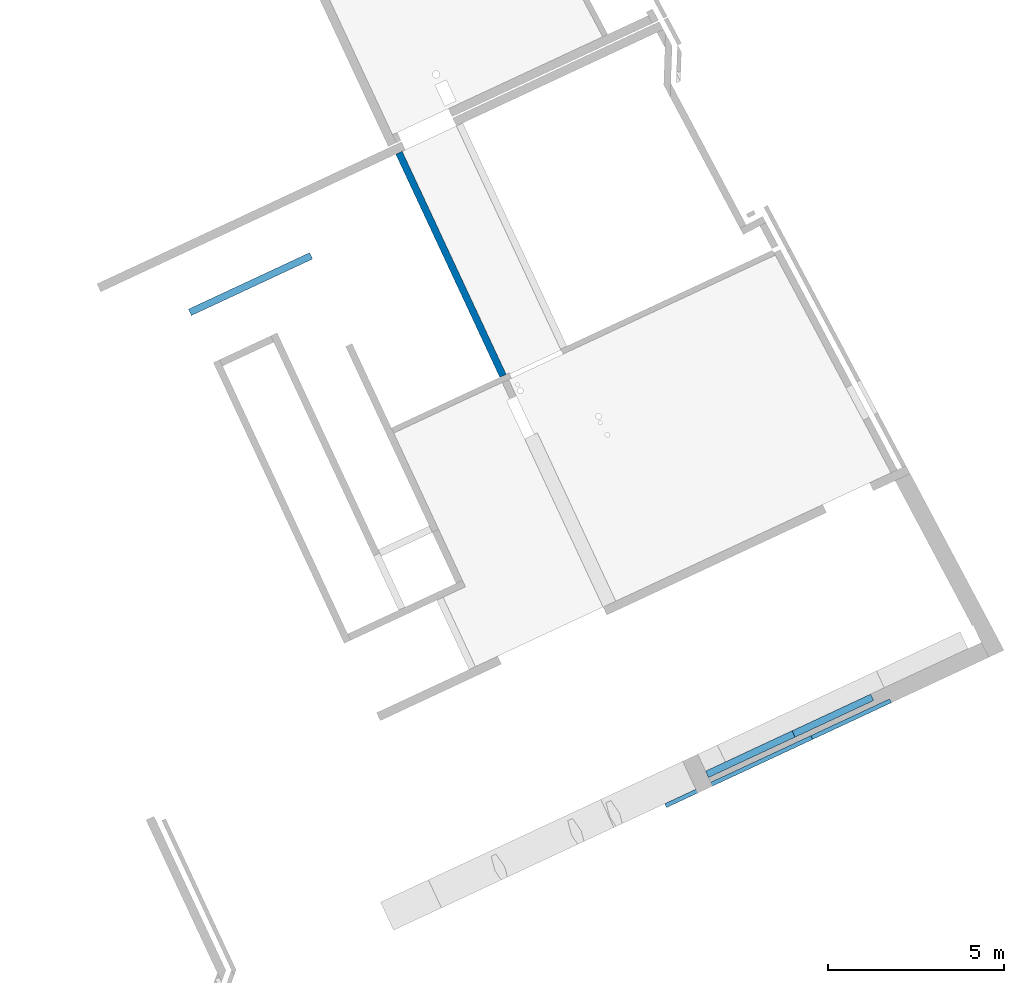
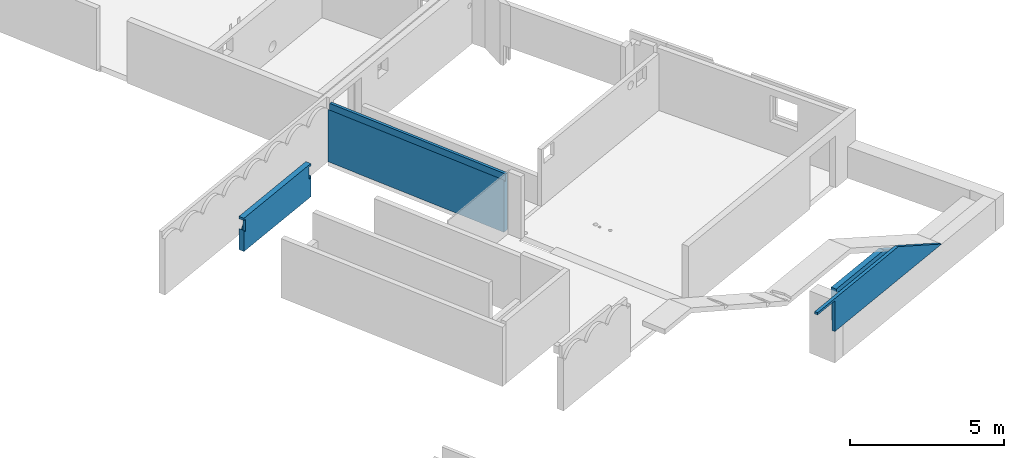
# One storey, part 7 of 13: 4 walls.
"""IFC2X3 building model written with IfcOpenShell, lengths in metres."""

from ifc_helpers import new_model, entity, si_unit, converted_unit, derived_unit, direction, frame, origin, place, context, subcontext, project, spatial, faceted_brep, material, layer, layer_set, type_object, element, save


model = new_model("IFC2X3")

# Units and contexts
model_context = context("Model", 3, precision=1e-05, world=origin(), true_north=direction((6.12303176911189e-17, 1.0)))
body_context = subcontext(model_context, "Body", "Model", "MODEL_VIEW")
ifc_project = project(units=[si_unit("LENGTHUNIT", "METRE"), si_unit("AREAUNIT", "SQUARE_METRE"), si_unit("VOLUMEUNIT", "CUBIC_METRE"), converted_unit("PLANEANGLEUNIT", "DEGREE", entity("IfcRatioMeasure", 0.0174532925199433), si_unit("PLANEANGLEUNIT", "RADIAN"), dimensions=[0, 0, 0, 0, 0, 0, 0]), si_unit("MASSUNIT", "GRAM", prefix="KILO"), derived_unit("MASSDENSITYUNIT", [(si_unit("MASSUNIT", "GRAM", prefix="KILO"), 1), (si_unit("LENGTHUNIT", "METRE"), -3)]), si_unit("TIMEUNIT", "SECOND"), si_unit("FREQUENCYUNIT", "HERTZ"), si_unit("THERMODYNAMICTEMPERATUREUNIT", "DEGREE_CELSIUS"), derived_unit("THERMALTRANSMITTANCEUNIT", [(si_unit("MASSUNIT", "GRAM", prefix="KILO"), 1), (si_unit("THERMODYNAMICTEMPERATUREUNIT", "KELVIN"), -1), (si_unit("TIMEUNIT", "SECOND"), -3)]), derived_unit("VOLUMETRICFLOWRATEUNIT", [(si_unit("LENGTHUNIT", "METRE"), 3), (si_unit("TIMEUNIT", "SECOND"), -1)]), si_unit("ELECTRICCURRENTUNIT", "AMPERE"), si_unit("ELECTRICVOLTAGEUNIT", "VOLT"), si_unit("POWERUNIT", "WATT"), si_unit("FORCEUNIT", "NEWTON", prefix="KILO"), si_unit("ILLUMINANCEUNIT", "LUX"), si_unit("LUMINOUSFLUXUNIT", "LUMEN"), si_unit("LUMINOUSINTENSITYUNIT", "CANDELA"), derived_unit("USERDEFINED", [(si_unit("MASSUNIT", "GRAM", prefix="KILO"), -1), (si_unit("LENGTHUNIT", "METRE"), -2), (si_unit("TIMEUNIT", "SECOND"), 3), (si_unit("LUMINOUSFLUXUNIT", "LUMEN"), 1)]), derived_unit("LINEARVELOCITYUNIT", [(si_unit("LENGTHUNIT", "METRE"), 1), (si_unit("TIMEUNIT", "SECOND"), -1)]), si_unit("PRESSUREUNIT", "PASCAL"), derived_unit("USERDEFINED", [(si_unit("LENGTHUNIT", "METRE"), -2), (si_unit("MASSUNIT", "GRAM", prefix="KILO"), 1), (si_unit("TIMEUNIT", "SECOND"), -2)])], contexts=[model_context])

# Site, building, storey
site_placement = place(None, frame((5.36960000000003, 43.3158000000006, 0.0), z_axis=(0.0, 0.0, 1.0), x_axis=(-0.422618261740703, 0.906307787036648, 0.0)))
site = spatial("IfcSite", under=ifc_project, at=site_placement, CompositionType="ELEMENT")
building_placement = place(site_placement, origin())
building = spatial("IfcBuilding", under=site, at=building_placement, CompositionType="ELEMENT")
storey_placement = place(building_placement, frame((0.0, 0.0, 2.56)))
storey = spatial("IfcBuildingStorey", under=building, at=storey_placement, CompositionType="ELEMENT", Elevation=2.56)

# Walls
ifc_material_1 = material(Name="C30/37 XC1")
ifc_layer_1 = layer(ifc_material_1, 0.2)
ifc_layer_set_1 = layer_set([ifc_layer_1])
wall_type_1 = type_object("IfcWallType", PredefinedType="STANDARD", material=ifc_layer_set_1)
wall_1_placement = place(storey_placement, frame((18.4756620018755, 16.9325037603587, 1.24), z_axis=(0.0, 0.0, 1.0), x_axis=(0.0, -1.0, 0.0)))
element("IfcWall", 1, at=wall_1_placement, inside=storey, type_object=wall_type_1, Name="XS1", context=body_context, shape_type="Brep", body=[
    faceted_brep([(0.0, 0.0999999999999994, 0.837944550462816), (0.0, 0.0999999999999994, 0.0), (0.0, -0.100000000000001, 0.0), (0.0, -0.100000000000001, 0.837944550462766), (0.0, 0.0999999999999994, 1.32), (0.0, 0.0999999999999994, 1.23000000001082), (0.0, -0.100000000000001, 1.23000000001082), (0.0, -0.100000000000001, 1.32), (3.80000000000002, -0.0999999999999987, 1.32), (3.80000000000002, -0.0999999999999987, 1.23000000001082), (3.80000000000002, 0.100000000000001, 1.23000000001082), (3.80000000000002, 0.100000000000001, 1.32), (3.8, -0.100000000000001, 0.838005736229164), (3.80000000000002, -0.100000000000001, 0.0), (3.80000000000002, 0.0999999999999991, 0.0), (3.80000000000002, 0.0999999999999991, 0.838005736229145), (0.0283089752587392, 0.0999999999999997, 0.795075967223185), (0.0529518380808455, 0.0999999999999999, 0.750000000000036), (0.14700398458924, 0.100000000000001, 0.750000000000049), (0.19017387657711, 0.0999999999999988, 0.823992611579494), (0.243180591673934, 0.0999999999999992, 0.891289225886868), (0.305001349272955, 0.0999999999999997, 0.950591334386263), (0.374443299150362, 0.1, 1.00075468495034), (0.450166537871279, 0.0999999999999987, 1.04081136055137), (0.530709962631984, 0.0999999999999993, 1.06998845551313), (0.614519463680605, 0.1, 1.08772298895984), (0.699977911335034, 0.100000000000001, 1.09367276770246), (0.785436358989464, 0.0999999999999991, 1.08772298895984), (0.869245860038085, 0.0999999999999998, 1.06998845551313), (0.949789284798787, 0.1, 1.04081136055136), (1.0255125235197, 0.0999999999999989, 1.00075468495033), (1.09495447339711, 0.0999999999999994, 0.950591334386246), (1.15677523099613, 0.0999999999999999, 0.891289225886849), (1.20978194609295, 0.1, 0.823992611579473), (1.25295183808084, 0.100000000000001, 0.75000000000004), (1.3470039845884, 0.0999999999999992, 0.750000000000053), (1.39017387657627, 0.0999999999999996, 0.823992611579498), (1.44318059167309, 0.1, 0.891289225886871), (1.50500134927211, 0.100000000000001, 0.950591334386266), (1.57444329914952, 0.0999999999999989, 1.00075468495035), (1.65016653787043, 0.0999999999999995, 1.04081136055137), (1.73070996263114, 0.1, 1.06998845551314), (1.81451946367976, 0.100000000000001, 1.08772298895984), (1.89997791133419, 0.0999999999999993, 1.09367276770246), (1.98543635898862, 0.1, 1.08772298895984), (2.06924586003724, 0.100000000000001, 1.06998845551313), (2.14978928479794, 0.0999999999999991, 1.04081136055136), (2.22551252351886, 0.0999999999999997, 1.00075468495033), (2.29495447339626, 0.1, 0.95059133438625), (2.35677523099528, 0.100000000000001, 0.891289225886852), (2.4097819460921, 0.099999999999999, 0.823992611579476), (2.45295183808, 0.0999999999999993, 0.750000000000043), (2.54700398458895, 0.1, 0.750000000000056), (2.59017387657682, 0.1, 0.823992611579502), (2.64318059167365, 0.0999999999999987, 0.891289225886875), (2.70500134927267, 0.0999999999999991, 0.95059133438627), (2.77444329915008, 0.0999999999999997, 1.00075468495035), (2.85016653787099, 0.1, 1.04081136055138), (2.9307099626317, 0.0999999999999988, 1.06998845551314), (3.01451946368032, 0.0999999999999994, 1.08772298895985), (3.09997791133475, 0.1, 1.09367276770246), (3.18543635898918, 0.100000000000001, 1.08772298895985), (3.2692458600378, 0.0999999999999993, 1.06998845551314), (3.3497892847985, 0.0999999999999999, 1.04081136055137), (3.42551252351942, 0.100000000000001, 1.00075468495034), (3.49495447339682, 0.0999999999999989, 0.950591334386253), (3.55677523099584, 0.0999999999999994, 0.891289225886856), (3.60978194609266, 0.0999999999999998, 0.82399261157948), (3.65295183808056, 0.1, 0.750000000000047), (3.74700398458951, 0.0999999999999987, 0.750000000000065), (3.77166631224638, 0.0999999999999989, 0.795108292968731), (0.200000000000026, -0.100000000000001, 0.0), (3.60000000000002, -0.1, 0.0), (3.77166631224638, -0.100000000000001, 0.795108292968731), (3.74700398458954, -0.100000000000001, 0.750000000000047), (3.70000000000003, -0.0999999999999995, 0.750000000000047), (3.70000000000003, -0.0999999999999995, 1.23000000001082), (0.100000000000027, -0.0999999999999998, 1.23000000001082), (0.100000000000027, -0.0999999999999998, 0.750000000000036), (0.0529518380808174, -0.1, 0.750000000000022), (0.0283089752587392, -0.1, 0.795075967223187), (0.100000000000027, 0.000111227717683329, 0.750000000000036), (0.100000000000027, 0.000111227717683329, 1.23000000001082), (0.614519463680624, 0.000111227717685228, 1.08772298895984), (0.530709962632006, 0.000111227717684566, 1.06998845551313), (0.450166537871301, 0.00011122771768393, 1.04081136055136), (0.374443299150385, 0.000111227717685498, 1.00075468495033), (0.305001349272981, 0.000111227717684949, 0.950591334386252), (0.24318059167396, 0.000111227717684461, 0.891289225886856), (0.190173876577138, 0.000111227717686208, 0.823992611579481), (0.147003984589268, 0.000111227717685867, 0.750000000000039), (3.70000000000003, 0.000111227717679284, 1.23000000001082), (3.70000000000003, 0.000111227717679284, 0.750000000000047), (3.65295183808056, 0.000111227717678912, 0.750000000000048), (3.60978194609269, 0.000111227717678571, 0.823992611579493), (3.55677523099587, 0.000111227717678152, 0.891289225886868), (3.49495447339685, 0.00011122771767983, 0.950591334386264), (3.42551252351944, 0.000111227717679281, 1.00075468495034), (3.34978928479852, 0.000111227717678683, 1.04081136055137), (3.26924586003782, 0.000111227717680212, 1.06998845551314), (3.1854363589892, 0.00011122771767955, 1.08772298895985), (3.09997791133477, 0.000111227717678875, 1.09367276770246), (3.01451946368034, 0.000111227717680366, 1.08772298895985), (2.93070996263172, 0.000111227717679704, 1.06998845551314), (2.85016653787102, 0.000111227717679067, 1.04081136055137), (2.7744432991501, 0.000111227717680635, 1.00075468495034), (2.70500134927269, 0.000111227717680086, 0.95059133438626), (2.64318059167367, 0.000111227717679598, 0.891289225886863), (2.59017387657685, 0.000111227717681345, 0.823992611579488), (2.54700398458898, 0.000111227717681004, 0.750000000000047), (2.45295183808, 0.000111227717680261, 0.750000000000044), (2.40978194609213, 0.00011122771767992, 0.82399261157949), (2.35677523099531, 0.000111227717681667, 0.891289225886864), (2.29495447339629, 0.000111227717681178, 0.95059133438626), (2.22551252351888, 0.00011122771768063, 1.00075468495034), (2.14978928479796, 0.000111227717682197, 1.04081136055137), (2.06924586003726, 0.000111227717681561, 1.06998845551314), (1.98543635898864, 0.000111227717680899, 1.08772298895984), (1.89997791133421, 0.000111227717682389, 1.09367276770246), (1.81451946367978, 0.000111227717681714, 1.08772298895984), (1.73070996263116, 0.000111227717683218, 1.06998845551313), (1.65016653787046, 0.000111227717682582, 1.04081136055137), (1.57444329914954, 0.000111227717681983, 1.00075468495034), (1.50500134927213, 0.0001112277176836, 0.950591334386256), (1.44318059167311, 0.000111227717683112, 0.891289225886859), (1.39017387657629, 0.000111227717682693, 0.823992611579484), (1.34700398458842, 0.000111227717682352, 0.750000000000043), (1.25295183808084, 0.000111227717683775, 0.750000000000041), (1.20978194609297, 0.000111227717683434, 0.823992611579487), (1.15677523099615, 0.000111227717683015, 0.891289225886861), (1.09495447339713, 0.000111227717682527, 0.950591334386257), (1.02551252351972, 0.000111227717684144, 1.00075468495034), (0.949789284798809, 0.000111227717683546, 1.04081136055137), (0.869245860038104, 0.000111227717685075, 1.06998845551313), (0.785436358989485, 0.000111227717684413, 1.08772298895984), (0.699977911335054, 0.000111227717683738, 1.09367276770246)], [[[0, 1, 2, 3]], [[4, 5, 6, 7]], [[8, 9, 10, 11]], [[12, 13, 14, 15]], [[11, 10, 5, 4]], [[14, 1, 0, 16, 17, 18, 19, 20, 21, 22, 23, 24, 25, 26, 27, 28, 29, 30, 31, 32, 33, 34, 35, 36, 37, 38, 39, 40, 41, 42, 43, 44, 45, 46, 47, 48, 49, 50, 51, 52, 53, 54, 55, 56, 57, 58, 59, 60, 61, 62, 63, 64, 65, 66, 67, 68, 69, 70, 15]], [[2, 71, 72, 13, 12, 73, 74, 75, 76, 9, 8, 7, 6, 77, 78, 79, 80, 3]], [[13, 72, 71, 2, 1, 14]], [[81, 78, 77, 82]], [[83, 84, 85, 86, 87, 88, 89, 90, 81, 82, 91, 92, 93, 94, 95, 96, 97, 98, 99, 100, 101, 102, 103, 104, 105, 106, 107, 108, 109, 110, 111, 112, 113, 114, 115, 116, 117, 118, 119, 120, 121, 122, 123, 124, 125, 126, 127, 128, 129, 130, 131, 132, 133, 134, 135]], [[92, 91, 76, 75]], [[0, 3, 80, 16]], [[80, 79, 17, 16]], [[90, 18, 17, 79, 78, 81]], [[35, 34, 127, 126]], [[52, 51, 110, 109]], [[92, 75, 74, 69, 68, 93]], [[21, 20, 88, 87]], [[88, 20, 19, 89]], [[86, 22, 21, 87]], [[84, 24, 23, 85]], [[84, 83, 25, 24]], [[86, 85, 23, 22]], [[83, 135, 26, 25]], [[89, 19, 18, 90]], [[133, 28, 27, 134]], [[133, 132, 29, 28]], [[132, 131, 30, 29]], [[31, 130, 129, 32]], [[129, 128, 33, 32]], [[30, 131, 130, 31]], [[127, 34, 33, 128]], [[27, 26, 135, 134]], [[38, 37, 124, 123]], [[124, 37, 36, 125]], [[122, 39, 38, 123]], [[120, 41, 40, 121]], [[120, 119, 42, 41]], [[122, 121, 40, 39]], [[119, 118, 43, 42]], [[125, 36, 35, 126]], [[44, 117, 116, 45]], [[45, 116, 115, 46]], [[114, 47, 46, 115]], [[48, 113, 112, 49]], [[112, 111, 50, 49]], [[113, 48, 47, 114]], [[50, 111, 110, 51]], [[44, 43, 118, 117]], [[55, 54, 107, 106]], [[107, 54, 53, 108]], [[105, 56, 55, 106]], [[103, 58, 57, 104]], [[103, 102, 59, 58]], [[105, 104, 57, 56]], [[102, 101, 60, 59]], [[108, 53, 52, 109]], [[61, 100, 99, 62]], [[62, 99, 98, 63]], [[97, 64, 63, 98]], [[65, 96, 95, 66]], [[95, 94, 67, 66]], [[96, 65, 64, 97]], [[67, 94, 93, 68]], [[61, 60, 101, 100]], [[69, 74, 73, 70]], [[73, 12, 15, 70]], [[82, 77, 6, 5, 10, 9, 76, 91]], [[7, 8, 11, 4]]]),
])
wall_2_placement = place(storey_placement, frame((13.0806608482374, 9.63252584902244, 0.0)))
element("IfcWall", 2, at=wall_2_placement, inside=storey, type_object=wall_type_1, context=body_context, shape_type="Brep", body=[
    faceted_brep([(0.0, -0.1, 2.26), (0.0, -0.1, 0.0), (6.99500115363823, -0.1, 0.0), (6.99500115363823, -0.1, 2.26), (6.99500115363823, 0.1, 2.07797514531719), (6.99500115363823, 0.1, 0.0), (0.0, 0.1, 0.0), (0.0, 0.1, 2.07797514531736), (0.433557821920404, 0.100000000000008, 2.07797514531725), (0.867115643840809, 0.100000000000015, 2.07797514531726), (1.30067346576121, 0.100000000000024, 2.07797514531727), (1.73423128768161, 0.10000000000003, 2.07797514531728), (2.18230786876935, 0.100000000000039, 2.07797514531728), (2.63038541609954, 0.100000000000047, 2.07797514531729), (3.07846199718727, 0.100000000000055, 2.0779751453173), (3.526538578275, 0.100000000000063, 2.0779751453173), (3.9600964001954, 0.10000000000007, 2.07797514531731), (4.39365422211581, 0.100000000000079, 2.07797514531732), (4.82721204403621, 0.100000000000086, 2.07797514531733), (5.26076986595661, 0.100000000000094, 2.07797514531733), (5.69432768787702, 0.100000000000102, 2.07797514531734), (6.12788550979742, 0.100000000000108, 2.07797514531735), (6.56144333171782, 0.100000000000117, 2.07797514531735), (6.99500115363823, 0.0716786686593203, 2.03509213092923), (6.99500115363823, 0.0470260732549413, 1.99000000000006), (6.99500115363823, 0.0, 1.99000000000006), (6.99500115363823, 0.0, 2.26), (0.0, 0.0, 2.26), (0.0, 0.0, 1.99000000000006), (0.650336831470202, 0.0716786687080233, 2.03509213101024), (0.0, 0.0716786686592694, 2.03509213092928), (0.0, 0.047026073254898, 1.99000000000006), (0.433558648077125, 0.0470260732548991, 1.99000000000006), (0.867116257742654, 0.0470260732549024, 1.99000000000006), (1.30793340287755, 0.0470260732549045, 1.99000000000006), (1.06731220015197, 0.0716786686180598, 2.03509213086084), (6.34466432103963, 0.0716786686051791, 2.03509213083939), (5.92768895128723, 0.0716786686870688, 2.03509213097539), (5.47754854785368, 0.0716786686890309, 2.03509213097865), (5.0605731802099, 0.0716786686857801, 2.03509213097326), (4.81995149301802, 0.0470260732549262, 1.99000000000006), (5.26076863815292, 0.0470260732549294, 1.99000000000006), (5.69432624781845, 0.0470260732549316, 1.99000000000006), (6.12788489589557, 0.0470260732549337, 1.99000000000006), (6.5614435439727, 0.047026073254937, 1.99000000000006), (1.51745260541256, 0.0718320732801446, 2.03534675499311), (1.74875054801246, 0.0470260732549078, 1.99000000000006), (1.92820135843559, 0.0719475024600278, 2.03553816377705), (3.33789482418835, 0.0721803966057545, 2.03592388031167), (3.74331699813099, 0.0721235462751263, 2.03582978420509), (3.49750005761332, 0.0470260732549186, 1.99000000000006), (2.81668652440331, 0.0715420773853271, 2.03486518005558), (4.61043277286679, 0.0718320733532728, 2.03534675511439), (3.93831720274821, 0.0470260732549208, 1.99000000000006), (4.17687488546737, 0.071980369929273, 2.03559263710658), (4.37913434788312, 0.0470260732549229, 1.99000000000006), (2.40453164386339, 0.0717579679227767, 2.03522378810314), (2.18593844461847, 0.0470260732549099, 1.99000000000006), (2.62312530281289, 0.0470260732549132, 1.99000000000006), (3.0603121610073, 0.0470260732549143, 1.99000000000006)], [[[0, 1, 2, 3]], [[4, 5, 6, 7, 8, 9, 10, 11, 12, 13, 14, 15, 16, 17, 18, 19, 20, 21, 22]], [[2, 1, 6, 5]], [[4, 23, 24, 25, 26, 3, 2, 5]], [[3, 26, 27, 0]], [[25, 28, 27, 26]], [[29, 30, 31, 32, 33, 34, 35]], [[36, 37, 38, 39, 40, 41, 42, 43, 44, 24, 23]], [[45, 46, 47]], [[36, 23, 4, 22, 21, 20, 19, 18, 39, 38, 37]], [[30, 29, 35, 10, 9, 8, 7]], [[48, 49, 15]], [[15, 49, 16]], [[49, 48, 50]], [[51, 48, 14]], [[39, 18, 52]], [[50, 53, 49]], [[54, 17, 16]], [[54, 53, 55]], [[45, 35, 34]], [[56, 47, 57]], [[55, 40, 52]], [[46, 45, 34]], [[10, 45, 11]], [[18, 17, 52]], [[35, 45, 10]], [[52, 17, 54]], [[39, 52, 40]], [[54, 16, 49]], [[52, 54, 55]], [[58, 51, 56]], [[54, 49, 53]], [[58, 59, 51]], [[11, 45, 47]], [[58, 56, 57]], [[12, 11, 47]], [[47, 46, 57]], [[12, 47, 56]], [[13, 12, 56]], [[15, 14, 48]], [[51, 13, 56]], [[13, 51, 14]], [[59, 50, 48]], [[51, 59, 48]], [[25, 24, 44, 43, 42, 41, 40, 55, 53, 50, 59, 58, 57, 46, 34, 33, 32, 31, 28]], [[0, 27, 28, 31, 30, 7, 6, 1]]]),
])
ifc_material_2 = material(Name="C30/37 XS1")
ifc_layer_2 = layer(ifc_material_2, 0.2)
ifc_layer_set_2 = layer_set([ifc_layer_2])
wall_type_2 = type_object("IfcWallType", PredefinedType="STANDARD", material=ifc_layer_set_2)
wall_3_placement = place(storey_placement, frame((0.370660848237436, 9.16252584900623, 1.25), z_axis=(0.0, 0.0, 1.0), x_axis=(0.0, -1.0, 0.0)))
element("IfcWall", 3, at=wall_3_placement, inside=storey, type_object=wall_type_2, context=body_context, shape_type="Brep", body=[
    faceted_brep([(0.0, -0.0999999999999944, 0.0), (5.17645999792742, -0.0999999999999944, 0.0), (2.71270832832371, -0.0999999999999944, 1.31), (0.0, -0.0999999999999944, 1.31), (5.17645999792741, 0.0999999999999944, 0.0), (0.0, 0.0999999999999944, 0.0), (0.0, 0.0999999999999944, 1.31), (2.71270832832371, 0.0999999999999944, 1.31)], [[[0, 1, 2, 3]], [[4, 5, 6, 7]], [[1, 0, 5, 4]], [[5, 0, 3, 6]], [[1, 4, 7, 2]], [[3, 2, 7, 6]]]),
])
ifc_layer_3 = layer(ifc_material_2, 0.12)
ifc_layer_set_3 = layer_set([ifc_layer_3])
wall_type_3 = type_object("IfcWallType", PredefinedType="STANDARD", material=ifc_layer_set_3)
wall_4_placement = place(storey_placement, frame((0.0606608482329806, 10.6064468527551, 1.25), z_axis=(0.0, 0.0, 1.0), x_axis=(0.0, -1.0, 0.0)))
element("IfcWall", 4, at=wall_4_placement, inside=storey, type_object=wall_type_3, context=body_context, shape_type="Brep", body=[
    faceted_brep([(0.0, -0.06, 1.22), (0.973921003748907, -0.06, 1.22), (0.973921003748907, -0.06, 0.990000000000118), (0.973921003748907, -0.06, 0.0), (1.44392100374891, -0.06, 0.0), (7.04639189531422, -0.06, 0.0), (4.58264022571052, -0.06, 1.31), (0.0, -0.06, 1.31), (7.04639189531422, 0.06, 0.0), (6.62038100167632, 0.06, 0.0), (1.44392100374891, 0.06, 0.0), (0.973921003748906, 0.06, 0.0), (0.973921003748906, 0.06, 1.01386194043188), (0.973921003748906, 0.06, 1.22), (0.0, 0.06, 1.22), (0.0, 0.06, 1.31), (4.58264022571052, 0.06, 1.31)], [[[0, 1, 2, 3, 4, 5, 6, 7]], [[8, 9, 10, 11, 12, 13, 14, 15, 16]], [[4, 3, 11, 10, 9, 8, 5]], [[14, 0, 7, 15]], [[1, 0, 14, 13]], [[2, 1, 13, 12, 11, 3]], [[5, 8, 16, 6]], [[7, 6, 16, 15]]]),
])

save(model, "model.ifc")
